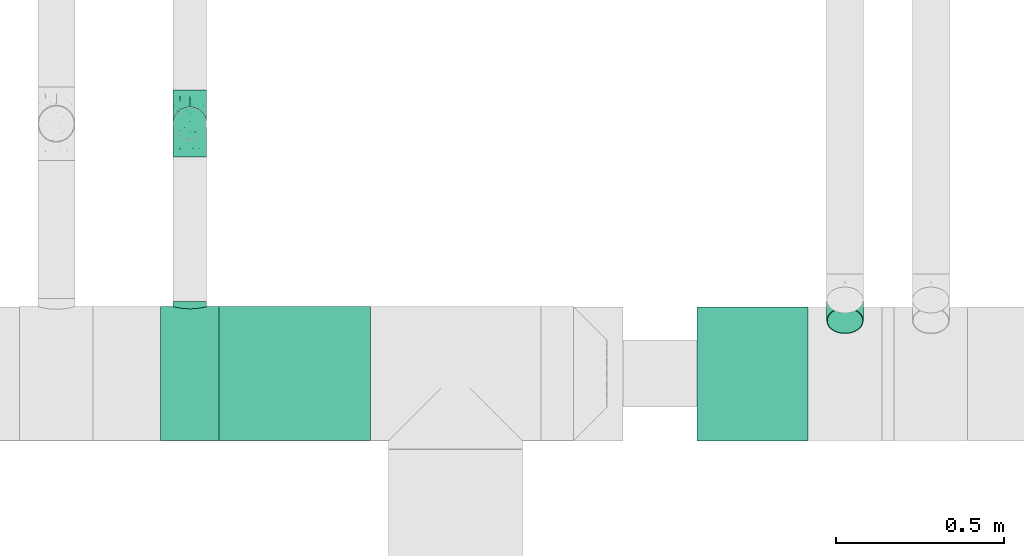
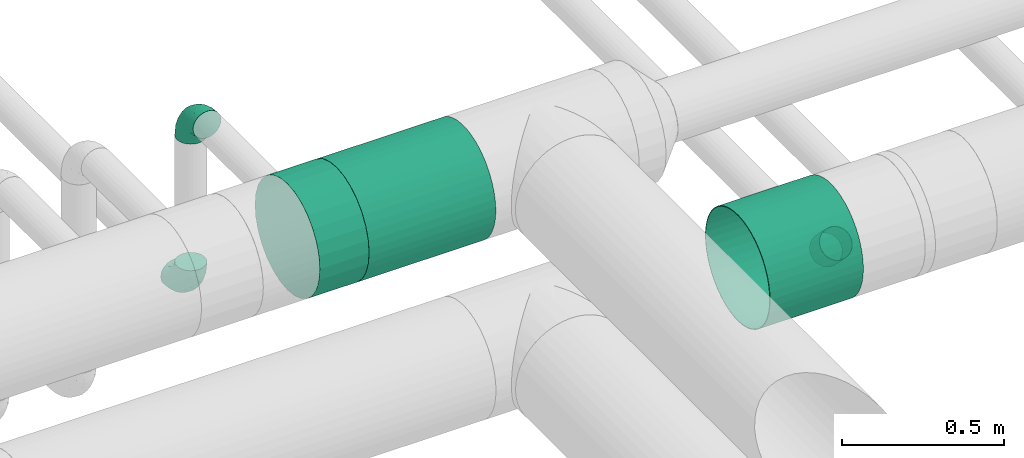
# One storey, part 83 of 91: 3 flow fittings, 3 flow segments.
"""IFC2X3 building model written with IfcOpenShell, lengths in millimetres."""

from ifc_helpers import new_model, entity, si_unit, converted_unit, derived_unit, direction, frame, origin_with_axes, origin_2d_with_axis, place, context, subcontext, project, spatial, hollow_circle, extrude, open_shell, surface_model, source, transform, mapped, material, layer, layer_set, layer_usage, type_object, element, save


model = new_model("IFC2X3")

# Units and contexts
model_context = context("Model", 3, precision=1e-05, world=origin_with_axes(), true_north=direction((0.0, 1.0)))
body_context = subcontext(model_context, "Body", "Model", "MODEL_VIEW")
ifc_project = project(units=[si_unit("AREAUNIT", "SQUARE_METRE"), si_unit("VOLUMEUNIT", "CUBIC_METRE", prefix="DECI"), si_unit("TIMEUNIT", "SECOND"), si_unit("THERMODYNAMICTEMPERATUREUNIT", "DEGREE_CELSIUS"), si_unit("PRESSUREUNIT", "PASCAL"), si_unit("MASSUNIT", "GRAM", prefix="KILO"), si_unit("LENGTHUNIT", "METRE", prefix="MILLI"), si_unit("POWERUNIT", "WATT"), si_unit("ELECTRICCURRENTUNIT", "AMPERE"), si_unit("ELECTRICVOLTAGEUNIT", "VOLT"), derived_unit("VOLUMETRICFLOWRATEUNIT", [(si_unit("VOLUMEUNIT", "CUBIC_METRE", prefix="DECI"), 1), (si_unit("TIMEUNIT", "SECOND"), -1)]), derived_unit("LINEARVELOCITYUNIT", [(si_unit("LENGTHUNIT", "METRE"), 1), (si_unit("TIMEUNIT", "SECOND"), -1)]), derived_unit("MASSDENSITYUNIT", [(si_unit("MASSUNIT", "GRAM", prefix="KILO"), 1), (si_unit("VOLUMEUNIT", "CUBIC_METRE"), -1)]), converted_unit("PLANEANGLEUNIT", "DEGREE", entity("IfcRatioMeasure", 0.01745), si_unit("PLANEANGLEUNIT", "RADIAN"), dimensions=[0, 0, 0, 0, 0, 0, 0])], contexts=[model_context])

# Site, building, storey
site_placement = place(None, origin_with_axes())
site = spatial("IfcSite", under=ifc_project, at=site_placement, CompositionType="ELEMENT")
building_placement = place(site_placement, origin_with_axes())
building = spatial("IfcBuilding", under=site, at=building_placement, Name="mc-building", CompositionType="ELEMENT")
storey_placement = place(building_placement, frame((0.0, 0.0, 8700.0), z_axis=(0.0, 0.0, 1.0), x_axis=(1.0, 0.0, 0.0)))
storey = spatial("IfcBuildingStorey", under=building, at=storey_placement, CompositionType="ELEMENT", Elevation=8700.0)

# Flow fittings
duct_fitting_type_1 = type_object("IfcDuctFittingType", Name="BU", PredefinedType="BEND")
shared_shape_1 = source(origin_with_axes(), body_context, "Body", "SurfaceModel", [
    surface_model("IfcShellBasedSurfaceModel", [(-100.0, 0.0, -50.0), (-100.0, -12.94095, -48.29629), (-100.0, 12.94095, -48.29629), (-100.0, 48.29629, 12.94095), (-100.0, 25.0, -43.30127), (-100.0, 43.30127, -25.0), (-100.0, 35.35534, -35.35534), (-100.0, -50.0, 0.0), (-100.0, -48.29629, 12.94095), (-100.0, -35.35534, -35.35534), (-100.0, -25.0, -43.30127), (-100.0, -48.29629, -12.94095), (-100.0, -43.30127, -25.0), (-100.0, 48.29629, -12.94095), (-100.0, 43.30127, 25.0), (-100.0, 35.35534, 35.35534), (-100.0, -12.94095, 48.29629), (-100.0, 25.0, 43.30127), (-100.0, 12.94095, 48.29629), (-100.0, -43.30127, 25.0), (-100.0, -35.35534, 35.35534), (-100.0, -25.0, 43.30127), (-100.0, 0.0, 50.0), (-100.0, 50.0, 0.0), (-12.94095, 100.0, -48.29629), (-50.0, 100.0, 0.0), (0.0, 100.0, -50.0), (-25.0, 100.0, -43.30127), (-35.35534, 100.0, -35.35534), (-43.30127, 100.0, -25.0), (35.35534, 100.0, -35.35534), (48.29629, 100.0, 12.94095), (25.0, 100.0, -43.30127), (12.94095, 100.0, -48.29629), (43.30127, 100.0, -25.0), (48.29629, 100.0, -12.94095), (50.0, 100.0, 0.0), (-48.29629, 100.0, -12.94095), (-48.29629, 100.0, 12.94095), (-43.30127, 100.0, 25.0), (-35.35534, 100.0, 35.35534), (0.0, 100.0, 50.0), (-25.0, 100.0, 43.30127), (-12.94095, 100.0, 48.29629), (43.30127, 100.0, 25.0), (35.35534, 100.0, 35.35534), (25.0, 100.0, 43.30127), (12.94095, 100.0, 48.29629), (-58.37939, 44.26324, 39.66767), (-69.67318, 34.70921, 41.41807), (-54.95374, 29.60867, 47.22379), (-69.0983, 4.89435, 50.0), (-81.95957, 10.85813, 49.17398), (-71.45436, 24.34004, 46.19398), (-63.80701, 16.86512, 49.12211), (-68.68567, 49.28345, 29.46598), (-84.79657, 41.61468, 30.43807), (-87.38486, 20.12422, 46.19398), (-19.0983, 41.22148, 50.0), (-16.69326, 64.07661, 49.13167), (-29.12893, 54.21835, 47.49497), (-58.07867, 67.98053, 16.35576), (-67.87621, 57.34916, 18.11021), (-57.82431, 60.07162, 27.24983), (-90.54273, 47.92896, 16.84479), (-84.64671, 51.44953, 9.54872), (-89.28706, 52.13093, 0.0), (-48.57141, 84.18266, 19.13417), (-80.49866, 49.85236, 19.13417), (-10.78328, 82.03604, 49.18466), (-4.89435, 69.0983, 50.0), (-52.13093, 89.28706, 0.0), (-51.49654, 84.66157, 9.29171), (-41.22148, 19.0983, 50.0), (-40.55308, 40.55308, 47.39468), (-84.25895, 32.24248, 39.66767), (-20.22969, 86.73423, 46.19398), (-32.70712, 82.37816, 39.66767), (-39.73574, 63.26064, 40.42863), (-24.76101, 70.36257, 46.19398), (-52.07527, 72.10209, 22.70672), (-53.34351, 76.64659, 14.58596), (-75.39343, 54.87419, 11.74349), (-45.34852, 49.56196, 42.93091), (-67.79776, 60.76145, 8.68857), (-41.23466, 86.33892, 30.43807), (-53.80602, 80.86583, 0.0), (-46.83364, 71.48109, 30.43807), (-59.22534, 72.75524, 0.0), (-51.32111, 56.42251, 36.03223), (-80.86583, 53.80602, 0.0), (-64.64466, 64.64466, 0.0), (-72.75524, 59.22534, 0.0), (-86.30081, 41.24353, -30.43807), (-84.6487, 51.45583, -9.51467), (-90.59087, 47.99544, -16.6365), (-82.00387, 32.80624, -39.66767), (-72.72667, 42.3343, -34.47953), (-69.0983, 4.89435, -50.0), (-66.13967, 17.89682, -48.73206), (-41.22148, 19.0983, -50.0), (-19.92688, 59.20071, -48.9627), (-4.89435, 69.0983, -50.0), (-19.0983, 41.22148, -50.0), (-32.19887, 84.44786, -39.66767), (-82.82099, 10.02515, -49.28938), (-41.61468, 84.79657, -30.43807), (-82.27704, 21.1002, -46.19398), (-64.48049, 30.28903, -45.01594), (-71.3903, 57.59661, -10.6727), (-22.65007, 76.4146, -46.19398), (-80.71765, 49.76775, -19.13417), (-63.27201, 52.13514, -30.43807), (-66.69474, 56.78794, -20.8562), (-57.71875, 61.44646, -25.88117), (-51.44953, 84.64671, -9.54872), (-49.85236, 80.49866, -19.13417), (-49.18799, 68.95983, -29.38061), (-52.50869, 28.2692, -48.00802), (-47.92896, 90.54273, -16.84479), (-11.48103, 81.33005, -49.0827), (-31.33477, 60.4193, -45.4939), (-39.98518, 39.98518, -47.65708), (-59.80479, 65.98498, -16.07996), (-63.94971, 39.6845, -40.19955), (-52.24546, 47.26788, -40.83149), (-55.20497, 74.81068, -11.71424), (-38.49923, 67.49589, -39.66767), (-52.04722, 57.72873, -34.6201), (-73.59404, 48.69992, -26.65479), (-47.57173, 4.1387, -49.13473), (29.5722, 42.84907, -27.71428), (13.52969, 19.02651, -30.72245), (13.59601, 32.77977, -38.42312), (27.49134, 63.71843, -37.951), (17.59627, 59.41659, -43.64098), (-63.95523, -42.22253, -17.81382), (-42.84907, -29.5722, -27.71428), (-25.90272, -27.798, -14.9099), (-4.1387, 47.57173, -49.13473), (-20.45037, 20.45037, -48.41225), (-68.61243, -10.20497, -47.82471), (-73.92917, -46.87327, -9.07697), (-73.47057, -38.0442, -29.22414), (-63.71843, -27.49134, -37.951), (-32.77977, -13.59601, -38.42312), (-8.32573, -9.86545, -25.36336), (-59.41659, -17.59627, -43.64098), (10.20497, 68.61244, -47.82471), (3.58524, 39.93936, -45.93923), (-12.17948, 12.17948, -43.75507), (-39.93936, -3.58524, -45.93923), (44.88888, 61.17714, 0.0), (38.05536, 43.47505, -9.02401), (45.64165, 67.74269, -9.06645), (17.21028, 10.65055, -15.96581), (-25.0, -29.90381, 0.0), (-1.12135, -11.13977, -11.07369), (38.0442, 73.47057, -29.22414), (32.46004, 37.55825, -18.52941), (42.22253, 63.95523, -17.81382), (29.90381, 25.0, 0.0), (6.06602, -6.06602, 0.0), (-61.17714, -44.88888, 0.0), (-45.78423, -39.05041, -8.65056), (-4.97501, 4.97501, -36.29915), (-63.95523, -42.22253, 17.81382), (-67.74269, -45.64165, 9.06645), (-37.55825, -32.46004, 18.52941), (-42.84907, -29.5722, 27.71428), (-73.47057, -38.0442, 29.22414), (-4.1387, 47.57173, 49.13473), (10.20497, 68.61244, 47.82471), (-39.93936, -3.58524, 45.93923), (-59.41659, -17.59627, 43.64098), (-32.77977, -13.59601, 38.42312), (-63.71843, -27.49134, 37.951), (-10.65055, -17.21028, 15.96581), (27.798, 25.90272, 14.9099), (11.13977, 1.12135, 11.07369), (46.87327, 73.92917, 9.07697), (39.05041, 45.78423, 8.65056), (-68.61243, -10.20497, 47.82471), (-47.57173, 4.1387, 49.13473), (3.58524, 39.93936, 45.93923), (-20.45037, 20.45037, 48.41225), (-12.17948, 12.17948, 43.75507), (9.86545, 8.32574, 25.36336), (-19.02651, -13.52969, 30.72245), (-43.47505, -38.05536, 9.02401), (29.5722, 42.84907, 27.71428), (42.22253, 63.95523, 17.81382), (38.0442, 73.47057, 29.22414), (27.49134, 63.71843, 37.951), (17.59627, 59.41659, 43.64098), (13.59601, 32.77977, 38.42312), (-4.97501, 4.97501, 36.29915)], [open_shell([[[0, 1, 2]], [[2, 3, 4]], [[5, 6, 3]], [[3, 6, 4]], [[2, 7, 8]], [[9, 7, 10]], [[1, 10, 7]], [[11, 7, 12]], [[9, 12, 7]], [[7, 2, 1]], [[13, 5, 3]], [[14, 3, 2]], [[15, 14, 2]], [[16, 17, 2]], [[15, 2, 17]], [[18, 17, 16]], [[8, 19, 2]], [[2, 19, 20]], [[2, 20, 21]], [[16, 2, 21]], [[16, 22, 18]], [[23, 13, 3]], [[24, 25, 26]], [[27, 25, 24]], [[25, 28, 29]], [[27, 28, 25]], [[30, 26, 31]], [[26, 30, 32]], [[32, 33, 26]], [[30, 31, 34]], [[35, 34, 31]], [[35, 31, 36]], [[37, 25, 29]], [[26, 38, 39]], [[26, 39, 40]], [[41, 40, 42]], [[40, 41, 26]], [[41, 42, 43]], [[26, 44, 31]], [[45, 44, 26]], [[46, 45, 26]], [[47, 46, 26]], [[47, 26, 41]], [[26, 25, 38]], [[48, 49, 50]], [[22, 51, 52]], [[53, 54, 50]], [[55, 56, 49]], [[56, 14, 15]], [[18, 57, 17]], [[58, 59, 60]], [[61, 62, 63]], [[3, 64, 65]], [[53, 52, 54]], [[3, 65, 66]], [[67, 39, 38]], [[56, 68, 64]], [[65, 64, 68]], [[69, 59, 70]], [[38, 71, 72]], [[73, 58, 74]], [[75, 49, 56]], [[76, 69, 43]], [[53, 57, 52]], [[77, 78, 79]], [[42, 76, 43]], [[43, 69, 41]], [[55, 68, 56]], [[15, 17, 75]], [[76, 77, 79]], [[80, 67, 81]], [[62, 82, 68]], [[60, 78, 83]], [[62, 84, 82]], [[85, 77, 40]], [[81, 67, 72]], [[86, 72, 71]], [[87, 85, 67]], [[61, 81, 88]], [[77, 42, 40]], [[78, 77, 87]], [[15, 75, 56]], [[83, 89, 48]], [[85, 40, 39]], [[62, 68, 55]], [[89, 87, 63]], [[83, 48, 50]], [[57, 75, 17]], [[49, 75, 53]], [[67, 85, 39]], [[87, 77, 85]], [[63, 62, 55]], [[89, 55, 48]], [[80, 63, 87]], [[66, 65, 90]], [[66, 23, 3]], [[84, 91, 92]], [[92, 90, 82]], [[65, 82, 90]], [[61, 84, 62]], [[92, 82, 84]], [[68, 82, 65]], [[3, 14, 64]], [[56, 64, 14]], [[38, 25, 71]], [[81, 72, 86]], [[38, 72, 67]], [[91, 61, 88]], [[80, 81, 61]], [[63, 80, 61]], [[67, 80, 87]], [[77, 76, 42]], [[79, 59, 69]], [[79, 69, 76]], [[41, 69, 70]], [[60, 59, 79]], [[58, 70, 59]], [[78, 60, 79]], [[58, 60, 74]], [[52, 57, 18]], [[75, 57, 53]], [[22, 52, 18]], [[52, 51, 54]], [[51, 73, 54]], [[50, 73, 74]], [[73, 50, 54]], [[50, 74, 83]], [[60, 83, 74]], [[89, 83, 78]], [[87, 89, 78]], [[55, 89, 63]], [[50, 49, 53]], [[55, 49, 48]], [[81, 86, 88]], [[91, 84, 61]], [[6, 5, 93]], [[90, 94, 66]], [[13, 94, 95]], [[96, 93, 97]], [[98, 99, 100]], [[96, 4, 6]], [[101, 102, 103]], [[28, 27, 104]], [[2, 105, 0]], [[104, 106, 28]], [[99, 105, 107]], [[108, 107, 96]], [[90, 109, 94]], [[107, 2, 4]], [[13, 66, 94]], [[27, 24, 110]], [[109, 111, 94]], [[112, 113, 114]], [[37, 115, 71]], [[116, 106, 117]], [[99, 118, 100]], [[116, 115, 119]], [[37, 119, 115]], [[24, 120, 110]], [[121, 110, 101]], [[119, 106, 116]], [[101, 110, 120]], [[122, 103, 100]], [[117, 123, 116]], [[124, 125, 108]], [[115, 116, 126]], [[106, 29, 28]], [[26, 102, 120]], [[127, 104, 110]], [[97, 124, 96]], [[125, 122, 118]], [[128, 127, 125]], [[96, 6, 93]], [[115, 126, 86]], [[117, 106, 127]], [[111, 113, 129]], [[95, 93, 5]], [[97, 129, 112]], [[110, 104, 27]], [[106, 104, 127]], [[96, 107, 4]], [[99, 107, 108]], [[99, 108, 118]], [[105, 99, 98]], [[112, 114, 128]], [[121, 125, 127]], [[13, 23, 66]], [[109, 90, 92]], [[94, 111, 95]], [[91, 123, 109]], [[129, 113, 112]], [[93, 95, 111]], [[5, 13, 95]], [[71, 115, 86]], [[71, 25, 37]], [[123, 91, 88]], [[126, 116, 123]], [[123, 88, 126]], [[86, 126, 88]], [[37, 29, 119]], [[106, 119, 29]], [[129, 93, 111]], [[124, 112, 125]], [[0, 105, 98]], [[107, 105, 2]], [[125, 118, 108]], [[100, 118, 122]], [[93, 129, 97]], [[113, 111, 109]], [[109, 123, 113]], [[114, 123, 117]], [[123, 114, 113]], [[128, 114, 117]], [[127, 128, 117]], [[112, 128, 125]], [[103, 122, 101]], [[110, 121, 127]], [[101, 122, 121]], [[125, 121, 122]], [[26, 120, 24]], [[101, 120, 102]], [[96, 124, 108]], [[92, 91, 109]], [[112, 124, 97]], [[100, 130, 98]], [[131, 132, 133]], [[32, 134, 135]], [[136, 137, 138]], [[139, 140, 103]], [[98, 141, 0]], [[142, 11, 136]], [[143, 144, 137]], [[7, 11, 142]], [[137, 145, 146]], [[144, 147, 145]], [[143, 136, 12]], [[12, 136, 11]], [[9, 143, 12]], [[148, 149, 139]], [[9, 10, 144]], [[10, 1, 147]], [[130, 141, 98]], [[103, 140, 100]], [[148, 135, 149]], [[150, 151, 140]], [[152, 153, 154]], [[130, 140, 151]], [[148, 26, 33]], [[147, 1, 141]], [[155, 146, 132]], [[156, 138, 157]], [[134, 30, 158]], [[150, 140, 149]], [[158, 30, 34]], [[30, 134, 32]], [[153, 159, 160]], [[131, 160, 159]], [[144, 145, 137]], [[36, 152, 154]], [[146, 138, 137]], [[155, 161, 162]], [[158, 160, 131]], [[133, 149, 135]], [[156, 163, 164]], [[163, 142, 164]], [[139, 103, 102]], [[153, 152, 161]], [[34, 35, 160]], [[162, 157, 155]], [[132, 165, 133]], [[157, 146, 155]], [[140, 130, 100]], [[141, 130, 151]], [[141, 151, 147]], [[141, 1, 0]], [[102, 26, 148]], [[140, 139, 149]], [[102, 148, 139]], [[135, 33, 32]], [[151, 150, 145]], [[10, 147, 144]], [[151, 145, 147]], [[145, 165, 146]], [[135, 148, 33]], [[133, 135, 134]], [[131, 133, 134]], [[133, 165, 150]], [[133, 150, 149]], [[145, 150, 165]], [[132, 131, 159]], [[146, 165, 132]], [[160, 158, 34]], [[134, 158, 131]], [[144, 143, 9]], [[136, 143, 137]], [[155, 153, 161]], [[154, 153, 160]], [[153, 155, 159]], [[132, 159, 155]], [[160, 35, 154]], [[36, 154, 35]], [[164, 136, 138]], [[7, 142, 163]], [[136, 164, 142]], [[156, 164, 138]], [[156, 157, 162]], [[146, 157, 138]], [[19, 8, 166]], [[7, 163, 167]], [[168, 169, 166]], [[166, 169, 170]], [[171, 172, 70]], [[173, 174, 175]], [[21, 176, 174]], [[177, 156, 162]], [[176, 20, 170]], [[170, 20, 19]], [[161, 178, 179]], [[152, 180, 181]], [[182, 173, 183]], [[22, 16, 182]], [[184, 185, 186]], [[183, 185, 73]], [[183, 73, 51]], [[177, 187, 188]], [[189, 168, 166]], [[187, 178, 190]], [[20, 176, 21]], [[161, 152, 181]], [[44, 191, 31]], [[44, 45, 192]], [[192, 191, 44]], [[180, 36, 31]], [[193, 194, 195]], [[46, 47, 194]], [[193, 195, 190]], [[193, 45, 46]], [[172, 41, 70]], [[185, 58, 73]], [[189, 163, 156]], [[163, 189, 167]], [[70, 58, 171]], [[184, 171, 185]], [[169, 188, 175]], [[180, 31, 191]], [[192, 193, 190]], [[191, 190, 178]], [[182, 174, 173]], [[194, 47, 172]], [[190, 195, 187]], [[186, 185, 173]], [[162, 179, 177]], [[188, 196, 175]], [[179, 187, 177]], [[185, 171, 58]], [[172, 171, 184]], [[172, 184, 194]], [[172, 47, 41]], [[51, 22, 182]], [[185, 183, 173]], [[51, 182, 183]], [[174, 16, 21]], [[184, 186, 195]], [[46, 194, 193]], [[184, 195, 194]], [[195, 196, 187]], [[174, 182, 16]], [[175, 174, 176]], [[169, 175, 176]], [[175, 196, 186]], [[175, 186, 173]], [[195, 186, 196]], [[188, 169, 168]], [[187, 196, 188]], [[166, 170, 19]], [[176, 170, 169]], [[193, 192, 45]], [[191, 192, 190]], [[177, 189, 156]], [[167, 189, 166]], [[189, 177, 168]], [[188, 168, 177]], [[166, 8, 167]], [[7, 167, 8]], [[181, 191, 178]], [[36, 180, 152]], [[191, 181, 180]], [[161, 181, 178]], [[161, 179, 162]], [[187, 179, 178]]])]),
])
for number, where, z_axis, x_axis, name in (
    (1, (31073.17179, 10827.25695, 1344.0), (1.0, 0.0, 0.0), (0.0, 0.0, 1.0), "BU"),
    (2, (31073.17179, 10827.25695, 668.0), (-1.0, 0.0, 0.0), (0.0, -1.0, 0.0), "BU"),
):
    element("IfcFlowFitting", number, at=place(storey_placement, frame(where, z_axis=z_axis, x_axis=x_axis)), inside=storey, type_object=duct_fitting_type_1, Name=name, context=body_context, shape_type="MappedRepresentation", body=[
        mapped(shared_shape_1, transform((0.0, 0.0, 0.0), scale=1.0)),
    ])
duct_fitting_type_2 = type_object("IfcDuctFittingType", PredefinedType="JUNCTION")
shared_shape_2 = source(origin_with_axes(), body_context, "Body", "SurfaceModel", [
    surface_model("IfcShellBasedSurfaceModel", [(0.0, -214.99999, -50.0), (12.94095, -214.99999, -48.29629), (-12.94095, -214.99999, -48.29629), (-48.29629, -214.99999, 12.94095), (-25.0, -214.99999, -43.30127), (-35.35534, -214.99999, -35.35534), (-43.30127, -214.99999, -25.0), (50.0, -214.99999, 0.0), (48.29629, -214.99999, 12.94095), (35.35534, -214.99999, -35.35534), (25.0, -214.99999, -43.30127), (48.29629, -214.99999, -12.94095), (43.30127, -214.99999, -25.0), (-48.29629, -214.99999, -12.94095), (-43.30127, -214.99999, 25.0), (-35.35534, -214.99999, 35.35534), (-25.0, -214.99999, 43.30127), (12.94095, -214.99999, 48.29629), (-12.94095, -214.99999, 48.29629), (43.30127, -214.99999, 25.0), (35.35534, -214.99999, 35.35534), (25.0, -214.99999, 43.30127), (0.0, -214.99999, 50.0), (-50.0, -214.99999, 0.0), (0.0, -193.64917, 50.0), (-11.1705, -193.97108, 48.73623), (-21.74582, -194.86632, 45.02354), (-31.19769, -196.14611, 39.07306), (-39.08243, -197.55364, 31.18594), (-45.03009, -198.81577, 21.73227), (-48.73904, -199.6885, 11.15822), (-50.0, -200.0, 0.0), (-45.02265, -198.81408, -21.74766), (-39.07054, -197.55128, -31.20084), (-48.73619, -199.68779, -11.17068), (-31.18275, -196.14373, -39.08499), (-21.73037, -194.8646, -45.031), (-11.15801, -193.97036, -48.73909), (0.0, -193.64917, -50.0), (11.1705, -193.97108, -48.73623), (21.74582, -194.86632, -45.02354), (31.19769, -196.14611, -39.07306), (39.08243, -197.55364, -31.18594), (45.03009, -198.81577, -21.73227), (48.73904, -199.6885, -11.15822), (50.0, -200.0, 0.0), (45.03009, -198.81577, 21.73227), (39.08243, -197.55364, 31.18594), (48.73904, -199.6885, 11.15822), (31.19769, -196.14611, 39.07306), (21.74582, -194.86632, 45.02354), (11.1705, -193.97108, 48.73623), (-87.5, 0.0, -200.0), (-87.5, -44.50419, -194.98559), (-87.5, 44.50419, -194.98559), (-87.5, 194.98559, 44.50419), (-87.5, 86.77674, -180.19378), (-87.5, 180.19378, -86.77674), (-87.5, 156.36629, -124.69796), (-87.5, 124.69796, -156.36629), (-87.5, -200.0, 0.0), (-87.5, -194.98559, 44.50419), (-87.5, -124.69796, -156.36629), (-87.5, -86.77674, -180.19378), (-87.5, -156.36629, -124.69796), (-87.5, -180.19378, -86.77674), (-87.5, -194.98559, -44.50419), (-87.5, 194.98559, -44.50419), (-87.5, 180.19378, 86.77674), (-87.5, 156.36629, 124.69796), (-87.5, 86.77674, 180.19378), (-87.5, 124.69796, 156.36629), (-87.5, 44.50419, 194.98559), (-87.5, 0.0, 200.0), (-87.5, -156.36629, 124.69796), (-87.5, -180.19378, 86.77674), (-87.5, -86.77674, 180.19378), (-87.5, -44.50419, 194.98559), (-87.5, -124.69796, 156.36629), (-87.5, 200.0, 0.0), (87.5, 0.0, -200.0), (87.5, 44.50419, -194.98559), (87.5, 86.77674, -180.19378), (87.5, 200.0, 0.0), (87.5, 156.36629, -124.69796), (87.5, 180.19378, -86.77674), (87.5, 124.69796, -156.36629), (87.5, -156.36629, -124.69796), (87.5, -194.98559, 44.50419), (87.5, -86.77674, -180.19378), (87.5, -44.50419, -194.98559), (87.5, -124.69796, -156.36629), (87.5, -180.19378, -86.77674), (87.5, -194.98559, -44.50419), (87.5, -200.0, 0.0), (87.5, 194.98559, -44.50419), (87.5, 194.98559, 44.50419), (87.5, 180.19378, 86.77674), (87.5, 156.36629, 124.69796), (87.5, 124.69796, 156.36629), (87.5, 86.77674, 180.19378), (87.5, 44.50419, 194.98559), (87.5, -156.36629, 124.69796), (87.5, -180.19378, 86.77674), (87.5, -86.77674, 180.19378), (87.5, -124.69796, 156.36629), (87.5, -44.50419, 194.98559), (87.5, 0.0, 200.0), (-87.5, -197.4928, -22.25209), (87.5, -197.4928, -22.25209), (87.5, -197.4928, 22.25209), (-87.5, -197.4928, 22.25209)], [open_shell([[[0, 1, 2]], [[2, 3, 4]], [[5, 3, 6]], [[4, 3, 5]], [[2, 7, 8]], [[9, 7, 10]], [[1, 10, 7]], [[11, 7, 12]], [[9, 12, 7]], [[7, 2, 1]], [[13, 6, 3]], [[14, 3, 2]], [[15, 14, 2]], [[16, 2, 17]], [[16, 15, 2]], [[16, 17, 18]], [[2, 8, 19]], [[2, 19, 20]], [[20, 21, 2]], [[17, 2, 21]], [[17, 22, 18]], [[23, 13, 3]], [[22, 24, 25]], [[18, 25, 26]], [[22, 25, 18]], [[16, 27, 15]], [[16, 18, 26]], [[27, 16, 26]], [[28, 29, 14]], [[30, 31, 23]], [[29, 30, 3]], [[15, 28, 14]], [[3, 14, 29]], [[23, 3, 30]], [[28, 15, 27]], [[32, 33, 6]], [[34, 32, 13]], [[31, 34, 23]], [[23, 34, 13]], [[32, 6, 13]], [[33, 5, 6]], [[4, 35, 36]], [[36, 37, 2]], [[38, 0, 37]], [[5, 35, 4]], [[2, 4, 36]], [[0, 2, 37]], [[35, 5, 33]], [[0, 38, 39]], [[1, 39, 40]], [[0, 39, 1]], [[10, 41, 9]], [[10, 1, 40]], [[41, 10, 40]], [[42, 43, 12]], [[44, 45, 7]], [[43, 44, 11]], [[9, 42, 12]], [[11, 12, 43]], [[7, 11, 44]], [[42, 9, 41]], [[46, 47, 19]], [[48, 46, 8]], [[45, 48, 7]], [[7, 48, 8]], [[46, 19, 8]], [[47, 20, 19]], [[21, 49, 50]], [[50, 51, 17]], [[24, 22, 51]], [[20, 49, 21]], [[17, 21, 50]], [[22, 17, 51]], [[49, 20, 47]], [[52, 53, 54]], [[54, 55, 56]], [[55, 57, 58]], [[58, 59, 55]], [[56, 55, 59]], [[54, 60, 61]], [[62, 60, 63]], [[54, 53, 63]], [[60, 64, 65]], [[65, 66, 60]], [[60, 62, 64]], [[63, 60, 54]], [[67, 57, 55]], [[55, 54, 68]], [[68, 54, 69]], [[70, 71, 69]], [[72, 70, 54]], [[70, 69, 54]], [[73, 72, 54]], [[74, 73, 75]], [[54, 61, 75]], [[76, 77, 73]], [[73, 78, 76]], [[74, 78, 73]], [[54, 75, 73]], [[79, 67, 55]], [[80, 81, 82]], [[83, 80, 82]], [[84, 85, 83]], [[83, 86, 84]], [[86, 83, 82]], [[87, 80, 88]], [[80, 89, 90]], [[80, 91, 89]], [[91, 80, 87]], [[87, 88, 92]], [[93, 92, 88]], [[93, 88, 94]], [[83, 85, 95]], [[83, 96, 97]], [[98, 80, 97]], [[99, 100, 80]], [[80, 100, 101]], [[98, 99, 80]], [[80, 101, 102]], [[102, 103, 80]], [[88, 80, 103]], [[101, 104, 105]], [[102, 101, 105]], [[106, 104, 101]], [[107, 106, 101]], [[83, 97, 80]], [[72, 107, 101]], [[70, 101, 100]], [[71, 100, 99]], [[73, 107, 72]], [[72, 101, 70]], [[100, 71, 70]], [[99, 69, 71]], [[68, 98, 97]], [[55, 97, 96]], [[79, 96, 83]], [[69, 98, 68]], [[68, 97, 55]], [[96, 79, 55]], [[98, 69, 99]], [[83, 95, 79]], [[85, 84, 58]], [[95, 85, 57]], [[67, 79, 95]], [[58, 57, 85]], [[67, 95, 57]], [[84, 59, 58]], [[56, 86, 82]], [[54, 82, 81]], [[52, 81, 80]], [[59, 86, 56]], [[56, 82, 54]], [[81, 52, 54]], [[86, 59, 84]], [[90, 53, 80]], [[89, 63, 90]], [[65, 87, 92]], [[89, 91, 62]], [[87, 64, 91]], [[92, 93, 39]], [[39, 38, 92]], [[53, 90, 63]], [[62, 63, 89]], [[53, 52, 80]], [[38, 37, 65]], [[34, 108, 32]], [[64, 87, 65]], [[37, 66, 65]], [[64, 62, 91]], [[38, 65, 92]], [[42, 109, 43]], [[93, 42, 41]], [[93, 109, 42]], [[41, 40, 93]], [[93, 40, 39]], [[94, 45, 44]], [[43, 109, 44]], [[44, 109, 94]], [[36, 35, 66]], [[33, 32, 108]], [[33, 66, 35]], [[36, 66, 37]], [[34, 60, 108]], [[31, 60, 34]], [[108, 66, 33]], [[45, 94, 48]], [[94, 110, 48]], [[110, 47, 46]], [[47, 110, 88]], [[49, 47, 88]], [[29, 111, 30]], [[60, 31, 30]], [[111, 60, 30]], [[27, 26, 61]], [[61, 111, 28]], [[61, 28, 27]], [[26, 25, 61]], [[49, 88, 50]], [[51, 103, 24]], [[48, 110, 46]], [[50, 88, 51]], [[74, 103, 102]], [[51, 88, 103]], [[104, 106, 77]], [[76, 105, 104]], [[78, 102, 105]], [[73, 106, 107]], [[25, 24, 75]], [[28, 111, 29]], [[75, 24, 103]], [[74, 75, 103]], [[25, 75, 61]], [[102, 78, 74]], [[105, 76, 78]], [[77, 76, 104]], [[106, 73, 77]]])]),
])
flow_fitting_placement = place(storey_placement, frame((31073.17179, 10080.96985, 1344.0), z_axis=(0.0, 0.0, 1.0), x_axis=(-1.0, 0.0, 0.0)))
element("IfcFlowFitting", 3, at=flow_fitting_placement, inside=storey, type_object=duct_fitting_type_2, context=body_context, shape_type="MappedRepresentation", body=[
    mapped(shared_shape_2, transform((0.0, 0.0, 0.0), scale=1.0)),
])

# Flow segments
ifc_material = material(Name="FZ1")
ifc_layer = layer(ifc_material, 0.0)
ifc_layer_set = layer_set([ifc_layer], Name="FZ1")
ifc_layer_usage = layer_usage(ifc_layer_set, "AXIS1", "POSITIVE", 0.0)
duct_segment_type_1 = type_object("IfcDuctSegmentType", PredefinedType="RIGIDSEGMENT")
shared_shape_3 = source(origin_with_axes(), body_context, "Body", "SweptSolid", [
    extrude(hollow_circle(Radius=55.0, WallThickness=2.0, at=origin_2d_with_axis()), frame((0.0, 0.0, 0.0), z_axis=(1.0, 0.0, 0.0), x_axis=(0.0, 1.0, 0.0)), (0.0, 0.0, 1.0), 87.2),
])
flow_segment_1_placement = place(storey_placement, frame((33028.54629, 10239.14939, 508.90097), z_axis=(0.0, -0.707107, -0.707107), x_axis=(0.0, 0.707107, -0.707107)))
element("IfcFlowSegment", 4, at=flow_segment_1_placement, inside=storey, type_object=duct_segment_type_1, material=ifc_layer_usage, context=body_context, shape_type="MappedRepresentation", body=[
    mapped(shared_shape_3, transform((0.0, 0.0, 0.0), scale=1.0)),
])
duct_segment_type_2 = type_object("IfcDuctSegmentType", Name="Safe", PredefinedType="RIGIDSEGMENT")
shared_shape_4 = source(origin_with_axes(), body_context, "Body", "SweptSolid", [
    extrude(hollow_circle(Radius=200.0, WallThickness=2.0, at=origin_2d_with_axis()), frame((0.0, 0.0, 0.0), z_axis=(1.0, 0.0, 0.0), x_axis=(0.0, 1.0, 0.0)), (0.0, 0.0, 1.0), 450.9),
])
flow_segment_2_placement = place(storey_placement, frame((31160.67179, 10080.96985, 1344.0), z_axis=(0.0, 0.0, 1.0), x_axis=(1.0, 0.0, 0.0)))
element("IfcFlowSegment", 5, at=flow_segment_2_placement, inside=storey, type_object=duct_segment_type_2, material=ifc_layer_usage, Name="Safe", context=body_context, shape_type="MappedRepresentation", body=[
    mapped(shared_shape_4, transform((0.0, 0.0, 0.0), scale=1.0)),
])
shared_shape_5 = source(origin_with_axes(), body_context, "Body", "SweptSolid", [
    extrude(hollow_circle(Radius=200.0, WallThickness=2.0, at=origin_2d_with_axis()), frame((0.0, 0.0, 0.0), z_axis=(1.0, 0.0, 0.0), x_axis=(0.0, 1.0, 0.0)), (0.0, 0.0, 1.0), 332.0),
])
flow_segment_3_placement = place(storey_placement, frame((32918.54629, 10080.05037, 668.0), z_axis=(0.0, 0.0, 1.0), x_axis=(-1.0, 0.0, 0.0)))
element("IfcFlowSegment", 6, at=flow_segment_3_placement, inside=storey, type_object=duct_segment_type_2, material=ifc_layer_usage, Name="Safe", context=body_context, shape_type="MappedRepresentation", body=[
    mapped(shared_shape_5, transform((0.0, 0.0, 0.0), scale=1.0)),
])

save(model, "model.ifc")
